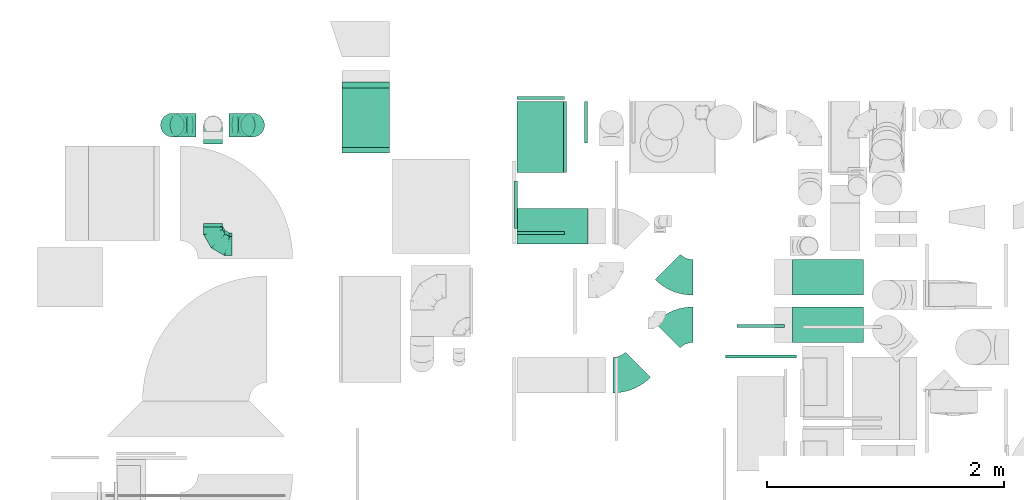
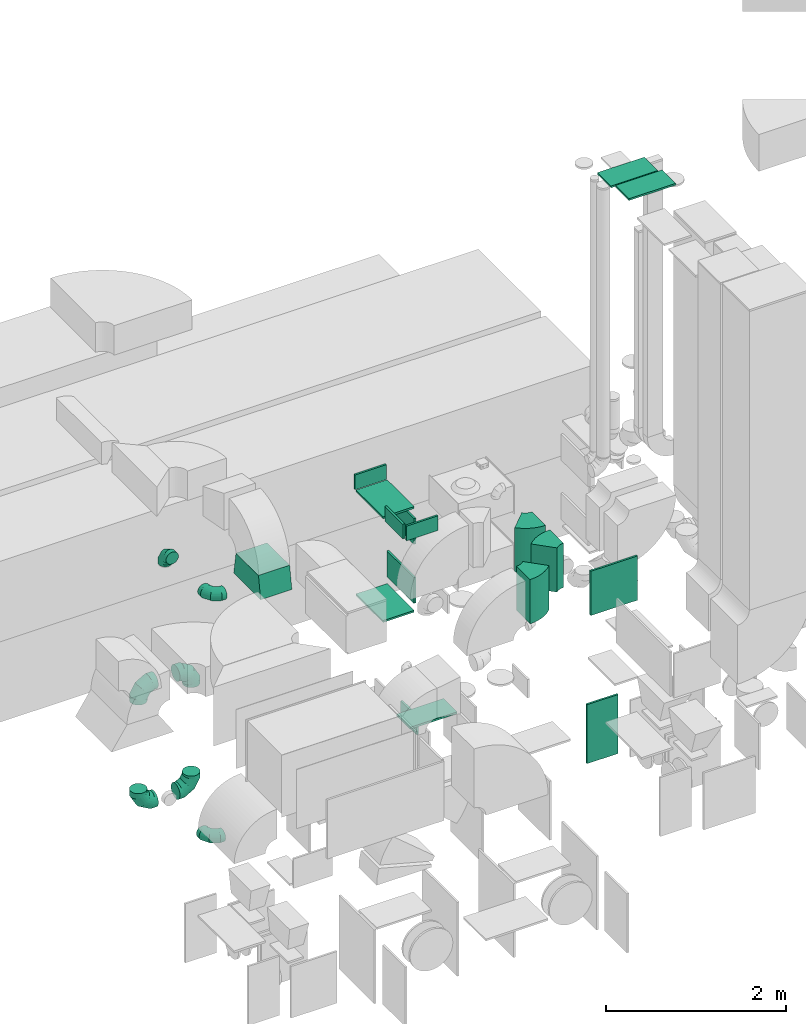
# One storey, part 17 of 59: 24 flow fittings.
"""IFC2X3 building model written with IfcOpenShell, lengths in millimetres."""

from ifc_helpers import new_model, entity, si_unit, converted_unit, derived_unit, direction, frame, frame_2d, origin, origin_2d_with_axis, place, context, subcontext, project, spatial, polyline, circle_curve, parameter, trimmed, segment, composite_curve, rectangle, outline, extrude, faceted_brep, source, transform, mapped, material, type_object, type_shapes, element, save


model = new_model("IFC2X3")

# Units and contexts
model_context = context("Model", 3, precision=0.01, world=origin(), true_north=direction((6.12303176911189e-17, 1.0)))
body_context = subcontext(model_context, "Body", "Model", "MODEL_VIEW")
ifc_project = project(units=[si_unit("LENGTHUNIT", "METRE", prefix="MILLI"), si_unit("AREAUNIT", "SQUARE_METRE"), si_unit("VOLUMEUNIT", "CUBIC_METRE"), converted_unit("PLANEANGLEUNIT", "DEGREE", entity("IfcRatioMeasure", 0.0174532925199433), si_unit("PLANEANGLEUNIT", "RADIAN"), dimensions=[0, 0, 0, 0, 0, 0, 0]), si_unit("MASSUNIT", "GRAM", prefix="KILO"), derived_unit("MASSDENSITYUNIT", [(si_unit("MASSUNIT", "GRAM", prefix="KILO"), 1), (si_unit("LENGTHUNIT", "METRE"), -3)]), derived_unit("MOMENTOFINERTIAUNIT", [(si_unit("LENGTHUNIT", "METRE"), 4)]), si_unit("TIMEUNIT", "SECOND"), si_unit("FREQUENCYUNIT", "HERTZ"), si_unit("THERMODYNAMICTEMPERATUREUNIT", "DEGREE_CELSIUS"), derived_unit("THERMALTRANSMITTANCEUNIT", [(si_unit("MASSUNIT", "GRAM", prefix="KILO"), 1), (si_unit("THERMODYNAMICTEMPERATUREUNIT", "KELVIN"), -1), (si_unit("TIMEUNIT", "SECOND"), -3)]), derived_unit("VOLUMETRICFLOWRATEUNIT", [(si_unit("LENGTHUNIT", "METRE"), 3), (si_unit("TIMEUNIT", "SECOND"), -1)]), derived_unit("MASSFLOWRATEUNIT", [(si_unit("MASSUNIT", "GRAM", prefix="KILO"), 1), (si_unit("TIMEUNIT", "SECOND"), -1)]), derived_unit("ROTATIONALFREQUENCYUNIT", [(si_unit("TIMEUNIT", "SECOND"), -1)]), si_unit("ELECTRICCURRENTUNIT", "AMPERE"), si_unit("ELECTRICVOLTAGEUNIT", "VOLT"), si_unit("POWERUNIT", "WATT"), si_unit("FORCEUNIT", "NEWTON", prefix="KILO"), si_unit("ILLUMINANCEUNIT", "LUX"), si_unit("LUMINOUSFLUXUNIT", "LUMEN"), si_unit("LUMINOUSINTENSITYUNIT", "CANDELA"), derived_unit("USERDEFINED", [(si_unit("MASSUNIT", "GRAM", prefix="KILO"), -1), (si_unit("LENGTHUNIT", "METRE"), -2), (si_unit("TIMEUNIT", "SECOND"), 3), (si_unit("LUMINOUSFLUXUNIT", "LUMEN"), 1)]), derived_unit("LINEARVELOCITYUNIT", [(si_unit("LENGTHUNIT", "METRE"), 1), (si_unit("TIMEUNIT", "SECOND"), -1)]), si_unit("PRESSUREUNIT", "PASCAL"), derived_unit("USERDEFINED", [(si_unit("LENGTHUNIT", "METRE"), -2), (si_unit("MASSUNIT", "GRAM", prefix="KILO"), 1), (si_unit("TIMEUNIT", "SECOND"), -2)]), derived_unit("LINEARFORCEUNIT", [(si_unit("MASSUNIT", "GRAM", prefix="KILO"), 1), (si_unit("LENGTHUNIT", "METRE"), 1), (si_unit("TIMEUNIT", "SECOND"), -2), (si_unit("LENGTHUNIT", "METRE"), -1)]), derived_unit("PLANARFORCEUNIT", [(si_unit("MASSUNIT", "GRAM", prefix="KILO"), 1), (si_unit("LENGTHUNIT", "METRE"), 1), (si_unit("TIMEUNIT", "SECOND"), -2), (si_unit("LENGTHUNIT", "METRE"), -2)])], contexts=[model_context])

# Site, building, storey
site_placement = place(None, origin())
site = spatial("IfcSite", under=ifc_project, at=site_placement, CompositionType="ELEMENT")
building_placement = place(site_placement, origin())
building = spatial("IfcBuilding", under=site, at=building_placement, CompositionType="ELEMENT")
storey_placement = place(building_placement, frame((0.0, 0.0, 28200.0)))
storey = spatial("IfcBuildingStorey", under=building, at=storey_placement, CompositionType="ELEMENT", Elevation=28200.0)

# Flow fittings
ifc_material = material()
duct_fitting_type_1 = type_object("IfcDuctFittingType", PredefinedType="NOTDEFINED", material=ifc_material)
shared_shape_1 = source(origin(), body_context, "Body", "SweptSolid", [
    extrude(rectangle(XDim=24.9999999999999, YDim=600.0, at=origin_2d_with_axis()), frame((12.5, 0.0, -200.0)), (0.0, 0.0, 1.0), 400.0),
])
type_shapes(duct_fitting_type_1, [shared_shape_1])
flow_fitting_1_placement = place(storey_placement, frame((46095.05, 12874.75, 2100.0), z_axis=(1.0, 0.0, 0.0), x_axis=(0.0, 0.0, -1.0)))
element("IfcFlowFitting", 1, at=flow_fitting_1_placement, inside=storey, type_object=duct_fitting_type_1, material=ifc_material, context=body_context, shape_type="MappedRepresentation", body=[
    mapped(shared_shape_1, transform((0.0, 0.0, 0.0), scale=1.0)),
])
duct_fitting_type_2 = type_object("IfcDuctFittingType", PredefinedType="NOTDEFINED", material=ifc_material)
shared_shape_2 = source(origin(), body_context, "Body", "SweptSolid", [
    extrude(rectangle(XDim=26.0960000000009, YDim=600.0, at=origin_2d_with_axis()), frame((6.95, 0.0, -200.0)), (0.0, 0.0, 1.0), 400.0),
])
type_shapes(duct_fitting_type_2, [shared_shape_2])
flow_fitting_2_placement = place(storey_placement, frame((46095.05, 12874.75, 3500.0), z_axis=(1.0, 0.0, 0.0), x_axis=(0.0, 0.0, -1.0)))
element("IfcFlowFitting", 2, at=flow_fitting_2_placement, inside=storey, type_object=duct_fitting_type_2, material=ifc_material, context=body_context, shape_type="MappedRepresentation", body=[
    mapped(shared_shape_2, transform((0.0, 0.0, 0.0), scale=1.0)),
])
duct_fitting_type_3 = type_object("IfcDuctFittingType", PredefinedType="NOTDEFINED", material=ifc_material)
shared_shape_3 = source(origin(), body_context, "Body", "SweptSolid", [
    extrude(rectangle(XDim=24.9999999999999, YDim=350.0, at=origin_2d_with_axis()), frame((12.5, 0.0, -125.0)), (0.0, 0.0, 1.0), 250.0),
])
type_shapes(duct_fitting_type_3, [shared_shape_3])
flow_fitting_3_placement = place(storey_placement, frame((46491.97, 12998.12, 325.0), z_axis=(0.0, 0.0, 1.0), x_axis=(-1.0, 0.0, 0.0)))
element("IfcFlowFitting", 3, at=flow_fitting_3_placement, inside=storey, type_object=duct_fitting_type_3, material=ifc_material, context=body_context, shape_type="MappedRepresentation", body=[
    mapped(shared_shape_3, transform((0.0, 0.0, 0.0), scale=1.0)),
])
duct_fitting_type_4 = type_object("IfcDuctFittingType", PredefinedType="NOTDEFINED", material=ifc_material)
shared_shape_4 = source(origin(), body_context, "Body", "SweptSolid", [
    extrude(rectangle(XDim=24.9999999999999, YDim=600.0, at=origin_2d_with_axis()), frame((12.5, 0.0, -300.0)), (0.0, 0.0, 1.0), 600.0),
])
type_shapes(duct_fitting_type_4, [shared_shape_4])
flow_fitting_4_placement = place(storey_placement, frame((47955.88, 11010.49, 2800.0), z_axis=(0.0, 0.0, 1.0), x_axis=(0.0, 1.0, 0.0)))
element("IfcFlowFitting", 4, at=flow_fitting_4_placement, inside=storey, type_object=duct_fitting_type_4, material=ifc_material, context=body_context, shape_type="MappedRepresentation", body=[
    mapped(shared_shape_4, transform((0.0, 0.0, 0.0), scale=1.0)),
])
duct_fitting_type_5 = type_object("IfcDuctFittingType", PredefinedType="NOTDEFINED", material=ifc_material)
shared_shape_5 = source(origin(), body_context, "Body", "SweptSolid", [
    extrude(rectangle(XDim=350.0, YDim=26.096, at=origin_2d_with_axis()), frame((6.95, 0.0, -300.0), z_axis=(0.0, 0.0, 1.0), x_axis=(0.0, -1.0, 0.0)), (0.0, 0.0, 1.0), 600.0),
])
type_shapes(duct_fitting_type_5, [shared_shape_5])
for number, where, z_axis, x_axis in (
    (5, (46295.05, 12874.75, 3170.0), (0.0, -1.0, 0.0), (1.0, 0.0, 0.0)),
    (6, (46295.05, 12874.75, 2370.0), (0.0, -1.0, 0.0), (1.0, 0.0, 0.0)),
):
    element("IfcFlowFitting", number, at=place(storey_placement, frame(where, z_axis=z_axis, x_axis=x_axis)), inside=storey, type_object=duct_fitting_type_5, material=ifc_material, context=body_context, shape_type="MappedRepresentation", body=[
        mapped(shared_shape_5, transform((0.0, 0.0, 0.0), scale=1.0)),
    ])
duct_fitting_type_6 = type_object("IfcDuctFittingType", PredefinedType="NOTDEFINED", material=ifc_material)
shared_shape_6 = source(origin(), body_context, "Body", "SweptSolid", [
    extrude(rectangle(XDim=24.9999999999999, YDim=400.0, at=origin_2d_with_axis()), frame((12.5, 0.0, -400.0)), (0.0, 0.0, 1.0), 800.0),
])
type_shapes(duct_fitting_type_6, [shared_shape_6])
flow_fitting_5_placement = place(storey_placement, frame((47955.03, 11268.46, 700.0), z_axis=(0.0, 0.0, 1.0), x_axis=(0.0, 1.0, 0.0)))
element("IfcFlowFitting", 7, at=flow_fitting_5_placement, inside=storey, type_object=duct_fitting_type_6, material=ifc_material, context=body_context, shape_type="MappedRepresentation", body=[
    mapped(shared_shape_6, transform((0.0, 0.0, 0.0), scale=1.0)),
])
duct_fitting_type_7 = type_object("IfcDuctFittingType", PredefinedType="NOTDEFINED", material=ifc_material)
shared_shape_7 = source(origin(), body_context, "Body", "SweptSolid", [
    extrude(rectangle(XDim=300.0, YDim=26.0960000000433, at=origin_2d_with_axis()), frame((6.95, 0.0, -300.0), z_axis=(0.0, 0.0, 1.0), x_axis=(0.0, -1.0, 0.0)), (0.0, 0.0, 1.0), 600.0),
])
type_shapes(duct_fitting_type_7, [shared_shape_7])
flow_fitting_6_placement = place(storey_placement, frame((46195.05, 12120.6, 1000.0), z_axis=(-1.0, 0.0, 0.0), x_axis=(0.0, 0.0, 1.0)))
element("IfcFlowFitting", 8, at=flow_fitting_6_placement, inside=storey, type_object=duct_fitting_type_7, material=ifc_material, context=body_context, shape_type="MappedRepresentation", body=[
    mapped(shared_shape_7, transform((0.0, 0.0, 0.0), scale=1.0)),
])
duct_fitting_type_8 = type_object("IfcDuctFittingType", PredefinedType="NOTDEFINED", material=ifc_material)
shared_shape_8 = source(origin(), body_context, "Body", "SweptSolid", [
    extrude(rectangle(XDim=24.9999999999999, YDim=400.0, at=origin_2d_with_axis()), frame((12.5, 0.0, -100.0)), (0.0, 0.0, 1.0), 200.0),
])
type_shapes(duct_fitting_type_8, [shared_shape_8])
for number, where, z_axis, x_axis in (
    (9, (46095.1, 12074.75, 3600.0), (0.0, 0.0, 1.0), (0.0, -1.0, 0.0)),
    (10, (46094.98, 13192.25, 3600.0), (0.0, 0.0, 1.0), (-9.9474455281492e-05, 0.999999995052416, 0.0)),
):
    element("IfcFlowFitting", number, at=place(storey_placement, frame(where, z_axis=z_axis, x_axis=x_axis)), inside=storey, type_object=duct_fitting_type_8, material=ifc_material, context=body_context, shape_type="MappedRepresentation", body=[
        mapped(shared_shape_8, transform((0.0, 0.0, 0.0), scale=1.0)),
    ])
duct_fitting_type_9 = type_object("IfcDuctFittingType", PredefinedType="NOTDEFINED", material=ifc_material)
shared_shape_9 = source(origin(), body_context, "Body", "SweptSolid", [
    extrude(outline(polyline([(-106.86, -271.26), (197.28, -271.26), (98.64, 320.58), (-189.06, 221.94), (-106.86, -271.26)])), frame((150.0, -200.0, 0.0), z_axis=(0.0, 1.0, 0.0), x_axis=(0.986393923832159, 0.0, 0.164398987305264)), (0.0, 0.0, 1.0), 400.0),
])
type_shapes(duct_fitting_type_9, [shared_shape_9])
flow_fitting_7_placement = place(storey_placement, frame((44620.31, 13037.27, 3100.0), z_axis=(0.0, -1.0, 0.0), x_axis=(0.0, 0.0, -1.0)))
element("IfcFlowFitting", 11, at=flow_fitting_7_placement, inside=storey, type_object=duct_fitting_type_9, material=ifc_material, context=body_context, shape_type="MappedRepresentation", body=[
    mapped(shared_shape_9, transform((0.0, 0.0, 0.0), scale=1.0)),
])
duct_fitting_type_10 = type_object("IfcDuctFittingType", PredefinedType="NOTDEFINED", material=ifc_material)
shared_shape_10 = source(origin(), body_context, "Body", "SweptSolid", [
    extrude(rectangle(XDim=24.9999999999999, YDim=300.0, at=origin_2d_with_axis()), frame((12.5, 0.0, -300.0)), (0.0, 0.0, 1.0), 600.0),
])
type_shapes(duct_fitting_type_10, [shared_shape_10])
for number, where, z_axis, x_axis in (
    (12, (48520.03, 11289.6, 7850.0), (-1.0, 0.0, 0.0), (0.0, 0.0, 1.0)),
    (13, (48520.03, 11689.6, 7780.0), (-1.0, 0.0, 0.0), (0.0, 0.0, 1.0)),
):
    element("IfcFlowFitting", number, at=place(storey_placement, frame(where, z_axis=z_axis, x_axis=x_axis)), inside=storey, type_object=duct_fitting_type_10, material=ifc_material, context=body_context, shape_type="MappedRepresentation", body=[
        mapped(shared_shape_10, transform((0.0, 0.0, 0.0), scale=1.0)),
    ])
duct_fitting_type_11 = type_object("IfcDuctFittingType", PredefinedType="NOTDEFINED", material=ifc_material)
shared_shape_11 = source(origin(), body_context, "Body", "SweptSolid", [
    extrude(rectangle(XDim=26.3228017580424, YDim=400.0, at=origin_2d_with_axis()), frame((6.95, 0.0, -100.0)), (0.0, 0.0, 1.0), 200.0),
])
type_shapes(duct_fitting_type_11, [shared_shape_11])
flow_fitting_8_placement = place(storey_placement, frame((45895.1, 12301.92, 3600.0), z_axis=(0.0, 0.0, -1.0), x_axis=(-1.0, 0.0, 0.0)))
element("IfcFlowFitting", 14, at=flow_fitting_8_placement, inside=storey, type_object=duct_fitting_type_11, material=ifc_material, context=body_context, shape_type="MappedRepresentation", body=[
    mapped(shared_shape_11, transform((0.0, 0.0, 0.0), scale=1.0)),
])
duct_fitting_type_12 = type_object("IfcDuctFittingType", PredefinedType="NOTDEFINED", material=ifc_material)
shared_shape_12 = source(origin(), body_context, "Body", "Brep", [
    faceted_brep([(-160.0, 0.0, -80.0), (-160.0, -20.71, -77.27), (-160.0, -40.0, -69.28), (-160.0, -56.57, -56.57), (-160.0, -69.28, -40.0), (-160.0, -77.27, -20.71), (-160.0, -80.0, 0.0), (-160.0, -77.27, 20.71), (-160.0, -69.28, 40.0), (-160.0, -56.57, 56.57), (-160.0, -40.0, 69.28), (-160.0, -20.71, 77.27), (-160.0, 0.0, 80.0), (-160.0, 20.71, 77.27), (-160.0, 40.0, 69.28), (-160.0, 56.57, 56.57), (-160.0, 69.28, 40.0), (-160.0, 77.27, 20.71), (-160.0, 80.0, 0.0), (-160.0, 77.27, -20.71), (-160.0, 69.28, -40.0), (-160.0, 56.57, -56.57), (-160.0, 40.0, -69.28), (-160.0, 20.71, -77.27), (-122.68, 20.71, 77.27), (-127.85, 40.0, 69.28), (-117.13, 0.0, 80.0), (-132.29, 56.57, 56.57), (-137.83, 77.27, 20.71), (-138.56, 80.0, 0.0), (-135.69, 69.28, 40.0), (-135.69, 69.28, -40.0), (-132.29, 56.57, -56.57), (-137.83, 77.27, -20.71), (-122.68, 20.71, -77.27), (-117.13, 0.0, -80.0), (-127.85, 40.0, -69.28), (-111.58, -20.71, -77.27), (-106.41, -40.0, -69.28), (-101.97, -56.57, -56.57), (-98.56, -69.28, -40.0), (-96.42, -77.27, -20.71), (-95.69, -80.0, 0.0), (-96.42, -77.27, 20.71), (-98.56, -69.28, 40.0), (-101.97, -56.57, 56.57), (-106.41, -40.0, 69.28), (-111.58, -20.71, 77.27), (-58.03, 58.03, 77.27), (-72.15, 72.15, 69.28), (-42.87, 42.87, 80.0), (-84.28, 84.28, 56.57), (-93.59, 93.59, 40.0), (-99.44, 99.44, 20.71), (-101.44, 101.44, 0.0), (-99.44, 99.44, -20.71), (-93.59, 93.59, -40.0), (-84.28, 84.28, -56.57), (-58.03, 58.03, -77.27), (-42.87, 42.87, -80.0), (-72.15, 72.15, -69.28), (-27.71, 27.71, -77.27), (-13.59, 13.59, -69.28), (-1.46, 1.46, -56.57), (7.85, -7.85, -40.0), (13.7, -13.7, -20.71), (15.69, -15.69, 0.0), (13.7, -13.7, 20.71), (7.85, -7.85, 40.0), (-1.46, 1.46, 56.57), (-13.59, 13.59, 69.28), (-27.71, 27.71, 77.27), (-20.71, 122.68, 77.27), (-40.0, 127.85, 69.28), (0.0, 117.13, 80.0), (-56.57, 132.29, 56.57), (-69.28, 135.69, 40.0), (-77.27, 137.83, 20.71), (-80.0, 138.56, 0.0), (-77.27, 137.83, -20.71), (-69.28, 135.69, -40.0), (-56.57, 132.29, -56.57), (-20.71, 122.68, -77.27), (0.0, 117.13, -80.0), (-40.0, 127.85, -69.28), (20.71, 111.58, -77.27), (40.0, 106.41, -69.28), (56.57, 101.97, -56.57), (69.28, 98.56, -40.0), (77.27, 96.42, -20.71), (80.0, 95.69, 0.0), (77.27, 96.42, 20.71), (69.28, 98.56, 40.0), (56.57, 101.97, 56.57), (40.0, 106.41, 69.28), (20.71, 111.58, 77.27), (-20.71, 160.0, -77.27), (-40.0, 160.0, -69.28), (-56.57, 160.0, -56.57), (-69.28, 160.0, -40.0), (-77.27, 160.0, -20.71), (-80.0, 160.0, 0.0), (-77.27, 160.0, 20.71), (-69.28, 160.0, 40.0), (-56.57, 160.0, 56.57), (-40.0, 160.0, 69.28), (-20.71, 160.0, 77.27), (0.0, 160.0, 80.0), (20.71, 160.0, 77.27), (40.0, 160.0, 69.28), (56.57, 160.0, 56.57), (69.28, 160.0, 40.0), (77.27, 160.0, 20.71), (80.0, 160.0, 0.0), (77.27, 160.0, -20.71), (69.28, 160.0, -40.0), (56.57, 160.0, -56.57), (40.0, 160.0, -69.28), (20.71, 160.0, -77.27), (0.0, 160.0, -80.0)], [[[0, 1, 2, 3, 4, 5, 6, 7, 8, 9, 10, 11, 12, 13, 14, 15, 16, 17, 18, 19, 20, 21, 22, 23]], [[24, 25, 14, 13]], [[26, 24, 13, 12]], [[14, 25, 27, 15]], [[28, 29, 18, 17]], [[30, 28, 17, 16]], [[15, 27, 30, 16]], [[20, 31, 32, 21]], [[33, 31, 20, 19]], [[18, 29, 33, 19]], [[34, 35, 0, 23]], [[36, 34, 23, 22]], [[32, 36, 22, 21]], [[1, 0, 35, 37]], [[2, 1, 37, 38]], [[3, 2, 38, 39]], [[5, 4, 40, 41]], [[6, 5, 41, 42]], [[39, 40, 4, 3]], [[6, 42, 43, 7]], [[7, 43, 44, 8]], [[8, 44, 45, 9]], [[9, 45, 46, 10]], [[10, 46, 47, 11]], [[26, 12, 11, 47]], [[48, 49, 25, 24]], [[50, 48, 24, 26]], [[27, 25, 49, 51]], [[52, 53, 28, 30]], [[51, 52, 30, 27]], [[29, 28, 53, 54]], [[55, 56, 31, 33]], [[54, 55, 33, 29]], [[32, 31, 56, 57]], [[58, 59, 35, 34]], [[60, 58, 34, 36]], [[57, 60, 36, 32]], [[37, 35, 59, 61]], [[38, 37, 61, 62]], [[39, 38, 62, 63]], [[41, 40, 64, 65]], [[42, 41, 65, 66]], [[63, 64, 40, 39]], [[43, 42, 66, 67]], [[44, 43, 67, 68]], [[68, 69, 45, 44]], [[46, 45, 69, 70]], [[47, 46, 70, 71]], [[26, 47, 71, 50]], [[72, 73, 49, 48]], [[74, 72, 48, 50]], [[51, 49, 73, 75]], [[76, 77, 53, 52]], [[75, 76, 52, 51]], [[54, 53, 77, 78]], [[79, 80, 56, 55]], [[78, 79, 55, 54]], [[57, 56, 80, 81]], [[82, 83, 59, 58]], [[84, 82, 58, 60]], [[81, 84, 60, 57]], [[61, 59, 83, 85]], [[62, 61, 85, 86]], [[63, 62, 86, 87]], [[65, 64, 88, 89]], [[66, 65, 89, 90]], [[87, 88, 64, 63]], [[67, 66, 90, 91]], [[68, 67, 91, 92]], [[92, 93, 69, 68]], [[70, 69, 93, 94]], [[71, 70, 94, 95]], [[50, 71, 95, 74]], [[96, 97, 98, 99, 100, 101, 102, 103, 104, 105, 106, 107, 108, 109, 110, 111, 112, 113, 114, 115, 116, 117, 118, 119]], [[72, 74, 107, 106]], [[73, 72, 106, 105]], [[75, 73, 105, 104]], [[77, 76, 103, 102]], [[78, 77, 102, 101]], [[75, 104, 103, 76]], [[78, 101, 100, 79]], [[79, 100, 99, 80]], [[80, 99, 98, 81]], [[84, 97, 96, 82]], [[82, 96, 119, 83]], [[84, 81, 98, 97]], [[118, 117, 86, 85]], [[119, 118, 85, 83]], [[116, 87, 86, 117]], [[88, 115, 114, 89]], [[89, 114, 113, 90]], [[115, 88, 87, 116]], [[112, 111, 92, 91]], [[113, 112, 91, 90]], [[111, 110, 93, 92]], [[95, 94, 109, 108]], [[74, 95, 108, 107]], [[110, 109, 94, 93]]]),
])
type_shapes(duct_fitting_type_12, [shared_shape_12])
for number, where, z_axis, x_axis in (
    (15, (43331.04, 11953.77, 3700.0), (0.0, 0.0, 1.0), (0.0, -1.0, 0.0)),
    (16, (43331.04, 12974.59, 3700.0), (-1.0, 0.0, 0.0), (0.0, 1.0, 0.0)),
    (17, (43331.04, 11983.87, 400.0), (0.0, 0.0, 1.0), (0.0, -1.0, 0.0)),
):
    element("IfcFlowFitting", number, at=place(storey_placement, frame(where, z_axis=z_axis, x_axis=x_axis)), inside=storey, type_object=duct_fitting_type_12, material=ifc_material, context=body_context, shape_type="MappedRepresentation", body=[
        mapped(shared_shape_12, transform((0.0, 0.0, 0.0), scale=1.0)),
    ])
duct_fitting_type_13 = type_object("IfcDuctFittingType", PredefinedType="NOTDEFINED", material=ifc_material)
shared_shape_13 = source(origin(), body_context, "Body", "Brep", [
    faceted_brep([(-200.0, 0.0, -100.0), (-200.0, -25.88, -96.59), (-200.0, -50.0, -86.6), (-200.0, -70.71, -70.71), (-200.0, -86.6, -50.0), (-200.0, -96.59, -25.88), (-200.0, -100.0, 0.0), (-200.0, -96.59, 25.88), (-200.0, -86.6, 50.0), (-200.0, -70.71, 70.71), (-200.0, -50.0, 86.6), (-200.0, -25.88, 96.59), (-200.0, 0.0, 100.0), (-200.0, 25.88, 96.59), (-200.0, 50.0, 86.6), (-200.0, 70.71, 70.71), (-200.0, 86.6, 50.0), (-200.0, 96.59, 25.88), (-200.0, 100.0, 0.0), (-200.0, 96.59, -25.88), (-200.0, 86.6, -50.0), (-200.0, 70.71, -70.71), (-200.0, 50.0, -86.6), (-200.0, 25.88, -96.59), (-153.35, 25.88, 96.59), (-159.81, 50.0, 86.6), (-146.41, 0.0, 100.0), (-165.36, 70.71, 70.71), (-172.29, 96.59, 25.88), (-173.21, 100.0, 0.0), (-169.62, 86.6, 50.0), (-169.62, 86.6, -50.0), (-165.36, 70.71, -70.71), (-172.29, 96.59, -25.88), (-153.35, 25.88, -96.59), (-146.41, 0.0, -100.0), (-159.81, 50.0, -86.6), (-139.48, -25.88, -96.59), (-133.01, -50.0, -86.6), (-127.46, -70.71, -70.71), (-123.21, -86.6, -50.0), (-120.53, -96.59, -25.88), (-119.62, -100.0, 0.0), (-120.53, -96.59, 25.88), (-123.21, -86.6, 50.0), (-127.46, -70.71, 70.71), (-133.01, -50.0, 86.6), (-139.48, -25.88, 96.59), (-72.54, 72.54, 96.59), (-90.19, 90.19, 86.6), (-53.59, 53.59, 100.0), (-105.35, 105.35, 70.71), (-116.99, 116.99, 50.0), (-124.3, 124.3, 25.88), (-126.79, 126.79, 0.0), (-124.3, 124.3, -25.88), (-116.99, 116.99, -50.0), (-105.35, 105.35, -70.71), (-72.54, 72.54, -96.59), (-53.59, 53.59, -100.0), (-90.19, 90.19, -86.6), (-34.64, 34.64, -96.59), (-16.99, 16.99, -86.6), (-1.83, 1.83, -70.71), (9.81, -9.81, -50.0), (17.12, -17.12, -25.88), (19.62, -19.62, 0.0), (17.12, -17.12, 25.88), (9.81, -9.81, 50.0), (-1.83, 1.83, 70.71), (-16.99, 16.99, 86.6), (-34.64, 34.64, 96.59), (-25.88, 153.35, 96.59), (-50.0, 159.81, 86.6), (0.0, 146.41, 100.0), (-70.71, 165.36, 70.71), (-86.6, 169.62, 50.0), (-96.59, 172.29, 25.88), (-100.0, 173.21, 0.0), (-96.59, 172.29, -25.88), (-86.6, 169.62, -50.0), (-70.71, 165.36, -70.71), (-25.88, 153.35, -96.59), (0.0, 146.41, -100.0), (-50.0, 159.81, -86.6), (25.88, 139.48, -96.59), (50.0, 133.01, -86.6), (70.71, 127.46, -70.71), (86.6, 123.21, -50.0), (96.59, 120.53, -25.88), (100.0, 119.62, 0.0), (96.59, 120.53, 25.88), (86.6, 123.21, 50.0), (70.71, 127.46, 70.71), (50.0, 133.01, 86.6), (25.88, 139.48, 96.59), (-25.88, 200.0, -96.59), (-50.0, 200.0, -86.6), (-70.71, 200.0, -70.71), (-86.6, 200.0, -50.0), (-96.59, 200.0, -25.88), (-100.0, 200.0, 0.0), (-96.59, 200.0, 25.88), (-86.6, 200.0, 50.0), (-70.71, 200.0, 70.71), (-50.0, 200.0, 86.6), (-25.88, 200.0, 96.59), (0.0, 200.0, 100.0), (25.88, 200.0, 96.59), (50.0, 200.0, 86.6), (70.71, 200.0, 70.71), (86.6, 200.0, 50.0), (96.59, 200.0, 25.88), (100.0, 200.0, 0.0), (96.59, 200.0, -25.88), (86.6, 200.0, -50.0), (70.71, 200.0, -70.71), (50.0, 200.0, -86.6), (25.88, 200.0, -96.59), (0.0, 200.0, -100.0)], [[[0, 1, 2, 3, 4, 5, 6, 7, 8, 9, 10, 11, 12, 13, 14, 15, 16, 17, 18, 19, 20, 21, 22, 23]], [[24, 25, 14, 13]], [[26, 24, 13, 12]], [[14, 25, 27, 15]], [[28, 29, 18, 17]], [[30, 28, 17, 16]], [[15, 27, 30, 16]], [[20, 31, 32, 21]], [[33, 31, 20, 19]], [[18, 29, 33, 19]], [[34, 35, 0, 23]], [[36, 34, 23, 22]], [[32, 36, 22, 21]], [[1, 0, 35, 37]], [[2, 1, 37, 38]], [[38, 39, 3, 2]], [[5, 4, 40, 41]], [[6, 5, 41, 42]], [[39, 40, 4, 3]], [[6, 42, 43, 7]], [[7, 43, 44, 8]], [[8, 44, 45, 9]], [[9, 45, 46, 10]], [[10, 46, 47, 11]], [[26, 12, 11, 47]], [[48, 49, 25, 24]], [[50, 48, 24, 26]], [[27, 25, 49, 51]], [[52, 53, 28, 30]], [[51, 52, 30, 27]], [[29, 28, 53, 54]], [[55, 56, 31, 33]], [[54, 55, 33, 29]], [[32, 31, 56, 57]], [[58, 59, 35, 34]], [[60, 58, 34, 36]], [[57, 60, 36, 32]], [[37, 35, 59, 61]], [[38, 37, 61, 62]], [[39, 38, 62, 63]], [[41, 40, 64, 65]], [[42, 41, 65, 66]], [[63, 64, 40, 39]], [[43, 42, 66, 67]], [[44, 43, 67, 68]], [[68, 69, 45, 44]], [[46, 45, 69, 70]], [[47, 46, 70, 71]], [[26, 47, 71, 50]], [[72, 73, 49, 48]], [[74, 72, 48, 50]], [[51, 49, 73, 75]], [[76, 77, 53, 52]], [[75, 76, 52, 51]], [[54, 53, 77, 78]], [[79, 80, 56, 55]], [[78, 79, 55, 54]], [[57, 56, 80, 81]], [[82, 83, 59, 58]], [[84, 82, 58, 60]], [[81, 84, 60, 57]], [[61, 59, 83, 85]], [[62, 61, 85, 86]], [[63, 62, 86, 87]], [[65, 64, 88, 89]], [[66, 65, 89, 90]], [[87, 88, 64, 63]], [[67, 66, 90, 91]], [[68, 67, 91, 92]], [[92, 93, 69, 68]], [[70, 69, 93, 94]], [[71, 70, 94, 95]], [[50, 71, 95, 74]], [[96, 97, 98, 99, 100, 101, 102, 103, 104, 105, 106, 107, 108, 109, 110, 111, 112, 113, 114, 115, 116, 117, 118, 119]], [[72, 74, 107, 106]], [[73, 72, 106, 105]], [[75, 73, 105, 104]], [[102, 101, 78, 77]], [[103, 102, 77, 76]], [[75, 104, 103, 76]], [[78, 101, 100, 79]], [[79, 100, 99, 80]], [[80, 99, 98, 81]], [[84, 97, 96, 82]], [[82, 96, 119, 83]], [[84, 81, 98, 97]], [[118, 117, 86, 85]], [[119, 118, 85, 83]], [[116, 87, 86, 117]], [[88, 115, 114, 89]], [[89, 114, 113, 90]], [[115, 88, 87, 116]], [[91, 90, 113, 112]], [[92, 91, 112, 111]], [[111, 110, 93, 92]], [[95, 94, 109, 108]], [[74, 95, 108, 107]], [[110, 109, 94, 93]]]),
])
type_shapes(duct_fitting_type_13, [shared_shape_13])
for number, where, z_axis, x_axis in (
    (18, (43665.23, 12974.59, 399.14), (0.0, 1.0, 0.0), (0.0, 0.0, -1.0)),
    (19, (42987.72, 12974.59, 399.14), (0.0, 1.0, 0.0), (-1.0, 0.0, 0.0)),
    (20, (42987.72, 12974.59, 1999.14), (0.0, 1.0, 0.0), (0.0, 0.0, 1.0)),
    (21, (43665.23, 12974.59, 1999.14), (0.0, -1.0, 0.0), (0.0, 0.0, 1.0)),
):
    element("IfcFlowFitting", number, at=place(storey_placement, frame(where, z_axis=z_axis, x_axis=x_axis)), inside=storey, type_object=duct_fitting_type_13, material=ifc_material, context=body_context, shape_type="MappedRepresentation", body=[
        mapped(shared_shape_13, transform((0.0, 0.0, 0.0), scale=1.0)),
    ])
duct_fitting_type_14 = type_object("IfcDuctFittingType", PredefinedType="NOTDEFINED", material=ifc_material)
shared_shape_14 = source(origin(), body_context, "Body", "SweptSolid", [
    extrude(outline(composite_curve([segment(polyline([(-193.93, -106.07), (106.07, -106.07)]), True, "CONTINUOUS"), segment(trimmed(circle_curve(frame_2d((256.07, -106.07), x_axis=(-0.707106781186553, 0.707106781186553)), 150.0), [parameter(0.0)], [parameter(45.0)], True, "PARAMETER"), False, "CONTINUOUS"), segment(polyline([(150.0, 0.0), (-62.13, 212.13)]), True, "CONTINUOUS"), segment(trimmed(circle_curve(frame_2d((256.07, -106.07), x_axis=(-0.707106781186553, 0.707106781186553)), 450.0), [parameter(0.0)], [parameter(45.0)], True, "PARAMETER"), True, "CONTINUOUS")], self_intersect=False)), frame((-18.2, 43.93, -300.0), z_axis=(0.0, 0.0, 1.0), x_axis=(-0.707106781186547, 0.707106781186548, 0.0)), (0.0, 0.0, 1.0), 600.0),
])
type_shapes(duct_fitting_type_14, [shared_shape_14])
for number, where, z_axis, x_axis in (
    (22, (47256.09, 11689.6, 3200.0), (0.0, 0.0, 1.0), (0.707106781186546, -0.707106781186549, 0.0)),
    (23, (47255.5, 11289.6, 3200.0), (0.0, 0.0, 1.0), (-1.0, 0.0, 0.0)),
):
    element("IfcFlowFitting", number, at=place(storey_placement, frame(where, z_axis=z_axis, x_axis=x_axis)), inside=storey, type_object=duct_fitting_type_14, material=ifc_material, context=body_context, shape_type="MappedRepresentation", body=[
        mapped(shared_shape_14, transform((0.0, 0.0, 0.0), scale=1.0)),
    ])
flow_fitting_9_placement = place(storey_placement, frame((46830.5, 10864.6, 3200.0)))
element("IfcFlowFitting", 24, at=flow_fitting_9_placement, inside=storey, type_object=duct_fitting_type_14, material=ifc_material, context=body_context, shape_type="MappedRepresentation", body=[
    mapped(shared_shape_14, transform((0.0, 0.0, 0.0), scale=1.0)),
])

save(model, "model.ifc")
